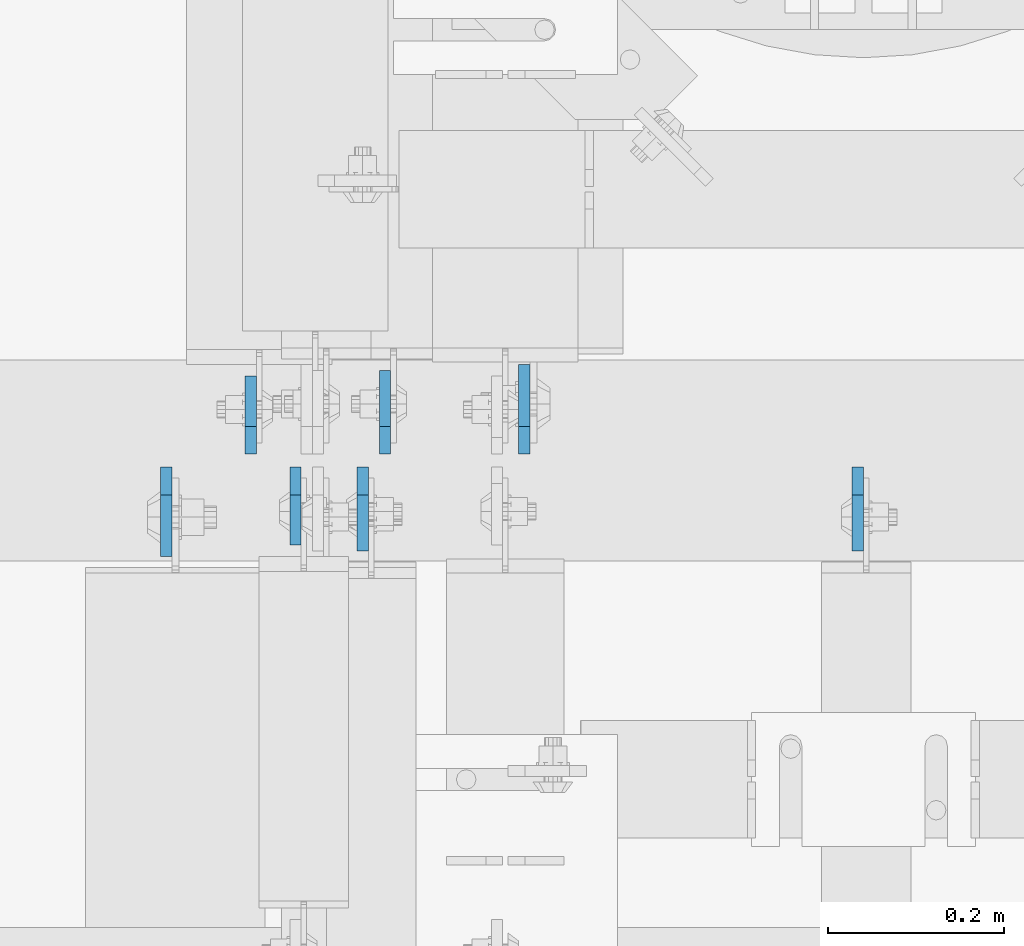
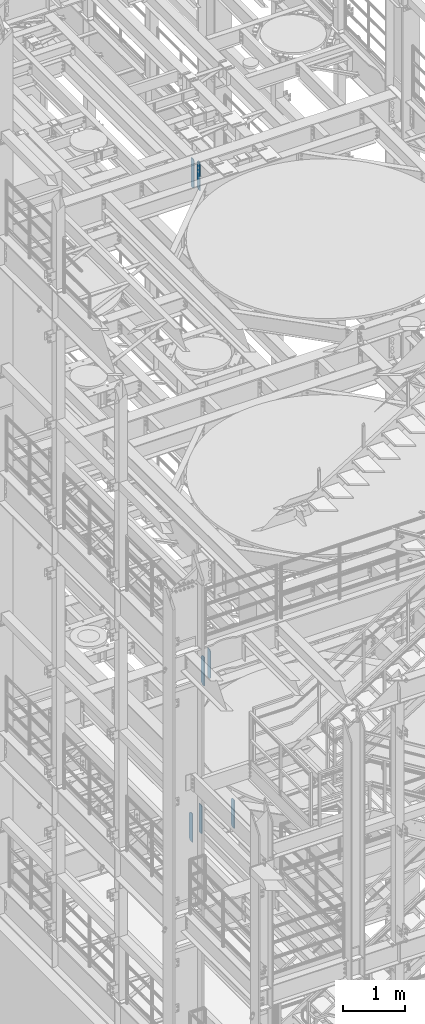
# One storey, part 1580 of 1876: 7 plates, 3 elements without a shape of their own.
"""IFC2X3 building model written with IfcOpenShell, lengths in millimetres."""

from ifc_helpers import new_model, si_unit, frame, origin_with_axes, place, context, subcontext, project, spatial, faceted_brep, material, type_object, element, aggregate, save


model = new_model("IFC2X3")

# Units and contexts
model_context = context("Model", 3, precision=1e-05, world=origin_with_axes())
body_context = subcontext(model_context, "Body", "Model", "MODEL_VIEW")
ifc_project = project(units=[si_unit("LENGTHUNIT", "METRE", prefix="MILLI"), si_unit("AREAUNIT", "SQUARE_METRE"), si_unit("VOLUMEUNIT", "CUBIC_METRE"), si_unit("MASSUNIT", "GRAM", prefix="KILO"), si_unit("TIMEUNIT", "SECOND"), si_unit("PLANEANGLEUNIT", "RADIAN"), si_unit("SOLIDANGLEUNIT", "STERADIAN"), si_unit("THERMODYNAMICTEMPERATUREUNIT", "DEGREE_CELSIUS"), si_unit("LUMINOUSINTENSITYUNIT", "LUMEN")], contexts=[model_context])

# Site, building, storey
site_placement = place(None, origin_with_axes())
site = spatial("IfcSite", under=ifc_project, at=site_placement, CompositionType="ELEMENT")
building_placement = place(site_placement, origin_with_axes())
building = spatial("IfcBuilding", under=site, at=building_placement, Name="Undefined", CompositionType="ELEMENT")
storey_placement = place(building_placement, origin_with_axes())
storey = spatial("IfcBuildingStorey", under=building, at=storey_placement, Name="Undefined", CompositionType="ELEMENT", Elevation=0.0)

# Assembly, plates
assembly_1_placement = place(storey_placement, origin_with_axes())
assembly_1 = element("IfcElementAssembly", 1, at=assembly_1_placement, inside=storey, Name="BEAM", AssemblyPlace="NOTDEFINED", PredefinedType="RIGID_FRAME")
ifc_material = material(Name="STEEL/A36")
plate_type_1 = type_object("IfcPlateType", PredefinedType="NOTDEFINED")
plate_1_placement = place(assembly_1_placement, frame((3775.07499990463, 1516.85625, 17386.3), z_axis=(0.0, 0.0, 1.0), x_axis=(0.0, -1.0, 0.0)))
plate_1 = element("IfcPlate", 2, at=plate_1_placement, type_object=plate_type_1, material=ifc_material, Name="PLATE", context=body_context, shape_type="Brep", body=[
    faceted_brep([(0.0, -6.34999999999991, 31.75), (0.0, -6.34999999999991, 539.75), (0.0, 6.34999999999991, 539.75), (0.0, 6.34999999999991, 31.75), (31.75, -6.34999999999991, 571.5), (31.75, 6.34999999999991, 571.5), (88.9000015258789, -6.34999999999991, 571.5), (88.9000015258789, 6.34999999999991, 571.5), (88.9000015258789, -6.34999999999991, 0.0), (88.9000015258789, 6.34999999999991, 0.0), (31.75, -6.34999999999991, 0.0), (31.75, 6.34999999999991, 0.0)], [[[0, 1, 2, 3]], [[1, 4, 5, 2]], [[4, 6, 7, 5]], [[6, 8, 9, 7]], [[8, 10, 11, 9]], [[10, 0, 3, 11]], [[5, 7, 9, 11, 3, 2]], [[10, 8, 6, 4, 1, 0]]]),
])
plate_2_placement = place(assembly_1_placement, frame((3724.27499990463, 1531.14375, 17386.3), z_axis=(0.0, 0.0, 1.0), x_axis=(0.0, 1.0, 0.0)))
plate_2 = element("IfcPlate", 3, at=plate_2_placement, type_object=plate_type_1, material=ifc_material, Name="PLATE", context=body_context, shape_type="Brep", body=[
    faceted_brep([(0.0, -6.34999999999991, 31.75), (0.0, -6.34999999999991, 539.75), (0.0, 6.34999999999991, 539.75), (0.0, 6.34999999999991, 31.75), (31.75, -6.34999999999991, 571.5), (31.75, 6.34999999999991, 571.5), (88.9000015258789, -6.34999999999991, 571.5), (88.9000015258789, 6.34999999999991, 571.5), (88.9000015258789, -6.34999999999991, 0.0), (88.9000015258789, 6.34999999999991, 0.0), (31.75, -6.34999999999991, 0.0), (31.75, 6.34999999999991, 0.0)], [[[0, 1, 2, 3]], [[1, 4, 5, 2]], [[4, 6, 7, 5]], [[6, 8, 9, 7]], [[8, 10, 11, 9]], [[10, 0, 3, 11]], [[5, 7, 9, 11, 3, 2]], [[10, 8, 6, 4, 1, 0]]]),
])
aggregate(assembly_1, [plate_1, plate_2])

# Assembly, plate
assembly_2_placement = place(storey_placement, origin_with_axes())
assembly_2 = element("IfcElementAssembly", 4, at=assembly_2_placement, inside=storey, Name="BEAM", AssemblyPlace="NOTDEFINED", PredefinedType="RIGID_FRAME")
plate_type_2 = type_object("IfcPlateType", PredefinedType="NOTDEFINED")
plate_3_placement = place(assembly_2_placement, frame((3851.27499990463, 1516.85625, 7558.0875), z_axis=(0.0, 0.0, 1.0), x_axis=(0.0, -1.0, 0.0)))
plate_3 = element("IfcPlate", 5, at=plate_3_placement, type_object=plate_type_2, material=ifc_material, Name="PLATE", context=body_context, shape_type="Brep", body=[
    faceted_brep([(0.0, -6.34999999999991, 31.75), (0.0, -6.35000000000036, 538.162475585938), (0.0, 6.35000000000036, 538.162475585938), (0.0, 6.34999999999991, 31.75), (31.75, -6.35000000000036, 569.912475585938), (31.75, 6.35000000000036, 569.912475585938), (95.25, -6.35000000000036, 569.912475585938), (95.25, 6.35000000000036, 569.912475585938), (95.25, -6.35000000000036, 0.0), (95.25, 6.35000000000036, 0.0), (31.75, -6.34999999999991, 0.0), (31.75, 6.34999999999991, 0.0)], [[[0, 1, 2, 3]], [[1, 4, 5, 2]], [[4, 6, 7, 5]], [[6, 8, 9, 7]], [[8, 10, 11, 9]], [[10, 0, 3, 11]], [[5, 7, 9, 11, 3, 2]], [[10, 8, 6, 4, 1, 0]]]),
])

# Assembly, plates
assembly_3_placement = place(storey_placement, origin_with_axes())
assembly_3 = element("IfcElementAssembly", 6, at=assembly_3_placement, inside=storey, Name="BEAM", AssemblyPlace="NOTDEFINED", PredefinedType="RIGID_FRAME")
plate_4_placement = place(assembly_3_placement, frame((4413.24999990463, 1516.85625, 4535.4875), z_axis=(0.0, 0.0, 1.0), x_axis=(0.0, -1.0, 0.0)))
plate_4 = element("IfcPlate", 7, at=plate_4_placement, type_object=plate_type_2, material=ifc_material, Name="PLATE", context=body_context, shape_type="Brep", body=[
    faceted_brep([(0.0, -6.34999999999991, 31.75), (0.0, -6.35000000000036, 538.162475585938), (0.0, 6.35000000000036, 538.162475585938), (0.0, 6.34999999999991, 31.75), (31.75, -6.35000000000036, 569.912475585938), (31.75, 6.35000000000036, 569.912475585938), (95.25, -6.35000000000036, 569.912475585938), (95.25, 6.35000000000036, 569.912475585938), (95.25, -6.35000000000036, 0.0), (95.25, 6.35000000000036, 0.0), (31.75, -6.34999999999991, 0.0), (31.75, 6.34999999999991, 0.0)], [[[0, 1, 2, 3]], [[1, 4, 5, 2]], [[4, 6, 7, 5]], [[6, 8, 9, 7]], [[8, 10, 11, 9]], [[10, 0, 3, 11]], [[5, 7, 9, 11, 3, 2]], [[10, 8, 6, 4, 1, 0]]]),
])
plate_5_placement = place(assembly_3_placement, frame((3876.67499990463, 1531.14375, 4535.4875), z_axis=(0.0, 0.0, 1.0), x_axis=(0.0, 1.0, 0.0)))
plate_5 = element("IfcPlate", 8, at=plate_5_placement, type_object=plate_type_2, material=ifc_material, Name="PLATE", context=body_context, shape_type="Brep", body=[
    faceted_brep([(0.0, -6.34999999999991, 31.75), (0.0, -6.35000000000036, 538.162475585938), (0.0, 6.35000000000036, 538.162475585938), (0.0, 6.34999999999991, 31.75), (31.75, -6.35000000000036, 569.912475585938), (31.75, 6.35000000000036, 569.912475585938), (95.25, -6.35000000000036, 569.912475585938), (95.25, 6.35000000000036, 569.912475585938), (95.25, -6.35000000000036, 0.0), (95.25, 6.35000000000036, 0.0), (31.75, -6.34999999999991, 0.0), (31.75, 6.34999999999991, 0.0)], [[[0, 1, 2, 3]], [[1, 4, 5, 2]], [[4, 6, 7, 5]], [[6, 8, 9, 7]], [[8, 10, 11, 9]], [[10, 0, 3, 11]], [[5, 7, 9, 11, 3, 2]], [[10, 8, 6, 4, 1, 0]]]),
])

# Plate
plate_type_3 = type_object("IfcPlateType", PredefinedType="NOTDEFINED")
plate_6_placement = place(assembly_2_placement, frame((4034.63087954625, 1531.14375, 7558.0875), z_axis=(0.0, 0.0, 1.0), x_axis=(0.0, 1.0, 0.0)))
plate_6 = element("IfcPlate", 9, at=plate_6_placement, type_object=plate_type_3, material=ifc_material, Name="PLATE", context=body_context, shape_type="Brep", body=[
    faceted_brep([(0.0, -6.34999999999991, 31.75), (0.0, -6.35000000000036, 538.162475585938), (0.0, 6.35000000000036, 538.162475585938), (0.0, 6.34999999999991, 31.75), (31.75, -6.35000000000036, 569.912475585938), (31.75, 6.35000000000036, 569.912475585938), (101.599998474121, -6.34999999999991, 569.912475585938), (101.599998474121, 6.34999999999991, 569.912475585938), (101.599998474121, -6.35000000000036, 0.0), (101.599998474121, 6.35000000000036, 0.0), (31.75, -6.34999999999991, 0.0), (31.75, 6.34999999999991, 0.0)], [[[0, 1, 2, 3]], [[1, 4, 5, 2]], [[4, 6, 7, 5]], [[6, 8, 9, 7]], [[8, 10, 11, 9]], [[10, 0, 3, 11]], [[5, 7, 9, 11, 3, 2]], [[10, 8, 6, 4, 1, 0]]]),
])

aggregate(assembly_2, [plate_3, plate_6])

plate_7_placement = place(assembly_3_placement, frame((3628.23124990463, 1516.85625, 4535.4875), z_axis=(0.0, 0.0, 1.0), x_axis=(0.0, -1.0, 0.0)))
plate_7 = element("IfcPlate", 10, at=plate_7_placement, type_object=plate_type_3, material=ifc_material, Name="PLATE", context=body_context, shape_type="Brep", body=[
    faceted_brep([(0.0, -6.34999999999991, 31.75), (0.0, -6.35000000000036, 538.162475585938), (0.0, 6.35000000000036, 538.162475585938), (0.0, 6.34999999999991, 31.75), (31.75, -6.35000000000036, 569.912475585938), (31.75, 6.35000000000036, 569.912475585938), (101.599998474121, -6.34999999999991, 569.912475585938), (101.599998474121, 6.34999999999991, 569.912475585938), (101.599998474121, -6.35000000000036, 0.0), (101.599998474121, 6.35000000000036, 0.0), (31.75, -6.34999999999991, 0.0), (31.75, 6.34999999999991, 0.0)], [[[0, 1, 2, 3]], [[1, 4, 5, 2]], [[4, 6, 7, 5]], [[6, 8, 9, 7]], [[8, 10, 11, 9]], [[10, 0, 3, 11]], [[5, 7, 9, 11, 3, 2]], [[10, 8, 6, 4, 1, 0]]]),
])

aggregate(assembly_3, [plate_7, plate_4, plate_5])

save(model, "model.ifc")
